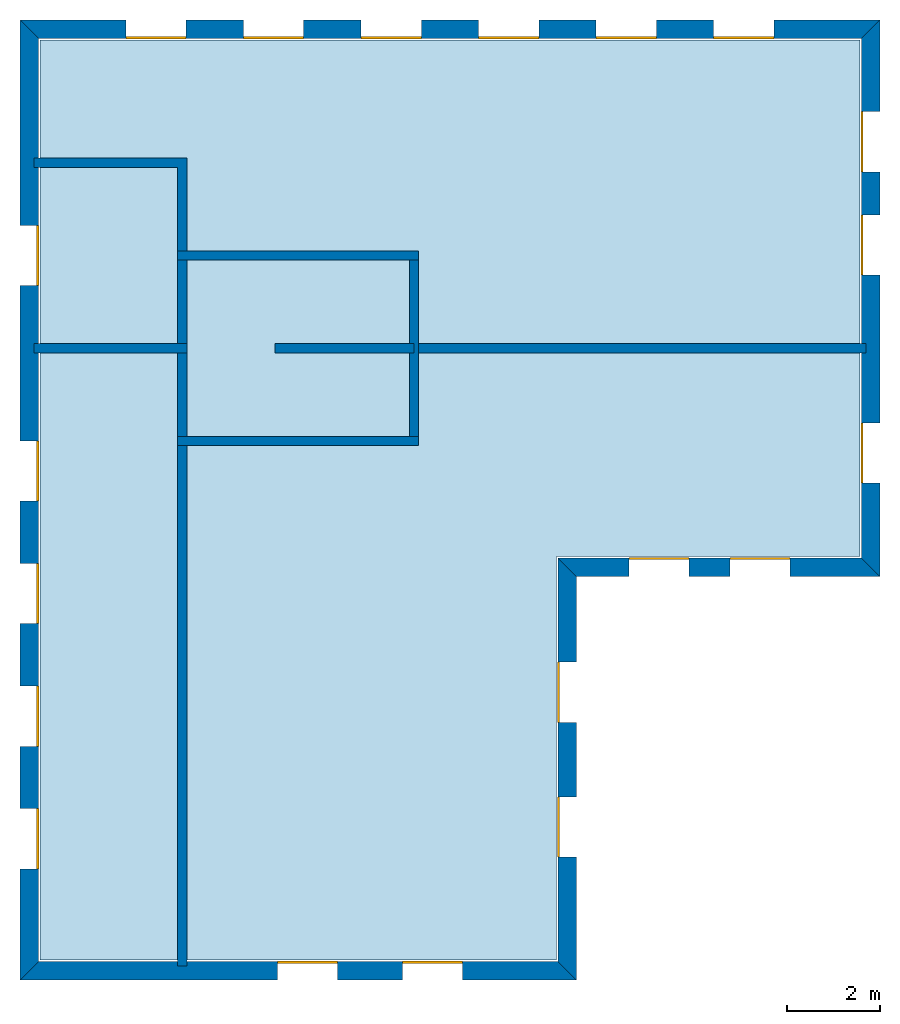
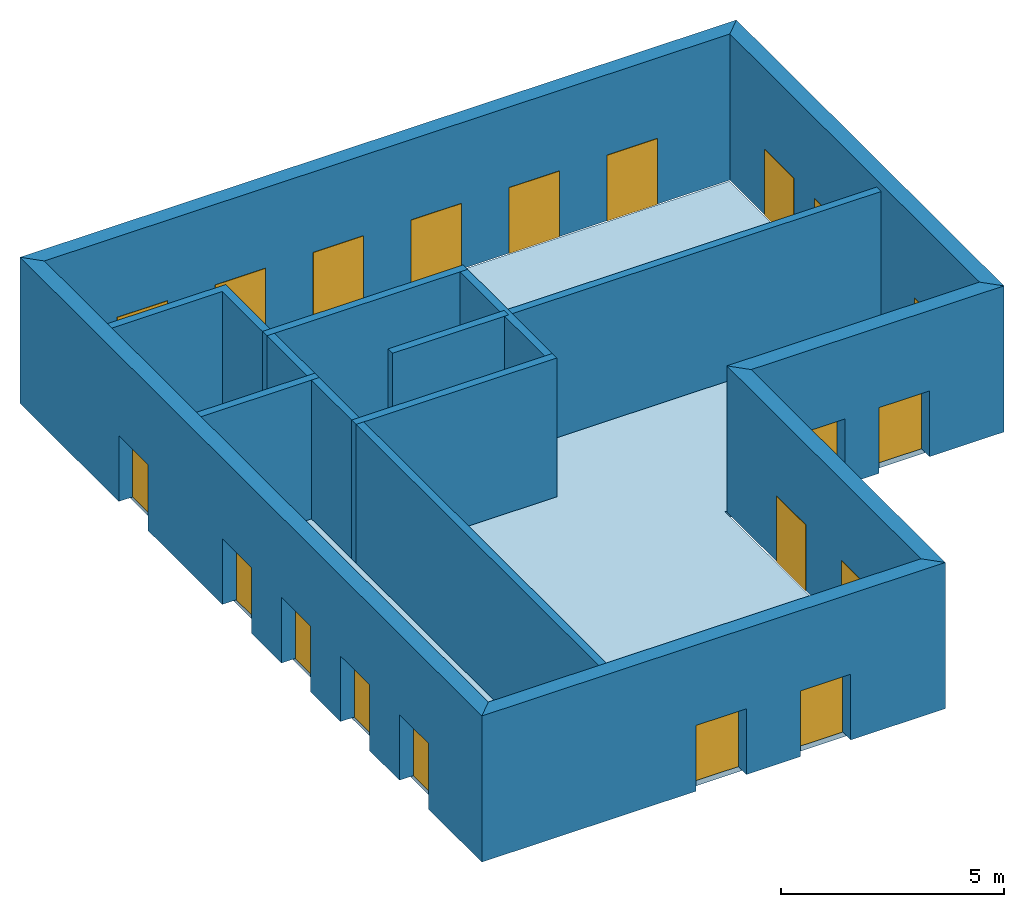
# One storey: 20 windows, 15 walls, 1 slab, 20 openings.
"""IFC4 building model written with IfcOpenShell, lengths in metres."""

from ifc_helpers import new_model, si_unit, origin_with_axes, place, context, subcontext, project, spatial, line, indexed_curve, outline, extrude, element, fill, save


model = new_model("IFC4")

# Units and contexts
model_context = context("Model", 3, precision=1e-05, world=origin_with_axes())
body_context = subcontext(model_context, "Body", "Model", "MODEL_VIEW")
ifc_project = project(units=[si_unit("VOLUMEUNIT", "CUBIC_METRE"), si_unit("LENGTHUNIT", "METRE"), si_unit("AREAUNIT", "SQUARE_METRE")], contexts=[model_context])

# Site, building, storey
site = spatial("IfcSite", under=ifc_project)
building = spatial("IfcBuilding", under=site, Name="Building 1")
storey_placement = place(None, origin_with_axes())
storey = spatial("IfcBuildingStorey", under=building, at=storey_placement, Name="01 Storey")

# Slab
slab_placement = place(storey_placement, origin_with_axes())
element("IfcSlab", 1, at=slab_placement, inside=storey, Name="Slab", context=body_context, shape_type="SweptSolid", body=[
    extrude(outline(indexed_curve([(15.563354, 14.685575), (22.109464, 14.685575), (22.109464, 25.825575), (4.423354, 25.825575), (4.423354, 5.9782), (15.563354, 5.9782)], segments=[line(1, 2), line(2, 3), line(3, 4), line(4, 5), line(5, 6)])), origin_with_axes(), (0.0, 0.0, -1.0), 0.2),
])

# Walls
wall_1_placement = place(storey_placement, origin_with_axes())
element("IfcWall", 2, at=wall_1_placement, inside=storey, Name="Wall", context=body_context, shape_type="SweptSolid", body=[
    extrude(outline(indexed_curve([(22.239464, 19.274943), (12.393354, 19.274943), (12.393354, 19.074943), (22.239464, 19.074943)], segments=[line(1, 2), line(2, 3), line(3, 4)])), origin_with_axes(), (0.0, 0.0, 1.0), 3.8),
])
wall_2_placement = place(storey_placement, origin_with_axes())
element("IfcWall", 3, at=wall_2_placement, inside=storey, Name="Wall", context=body_context, shape_type="SweptSolid", body=[
    extrude(outline(indexed_curve([(7.593354, 17.274943), (7.393354, 17.274943), (7.393354, 5.8482), (7.593354, 5.8482)], segments=[line(1, 2), line(2, 3), line(3, 4)])), origin_with_axes(), (0.0, 0.0, 1.0), 3.8),
])
wall_3_placement = place(storey_placement, origin_with_axes())
element("IfcWall", 4, at=wall_3_placement, inside=storey, Name="Wall", context=body_context, shape_type="SweptSolid", body=[
    extrude(outline(indexed_curve([(7.593354, 19.274943), (4.293354, 19.274943), (4.293354, 19.074943), (7.593354, 19.074943)], segments=[line(1, 2), line(2, 3), line(3, 4)])), origin_with_axes(), (0.0, 0.0, 1.0), 3.8),
])
wall_4_placement = place(storey_placement, origin_with_axes())
element("IfcWall", 5, at=wall_4_placement, inside=storey, Name="Wall", context=body_context, shape_type="SweptSolid", body=[
    extrude(outline(indexed_curve([(7.593354, 23.274943), (4.293354, 23.274943), (4.293354, 23.074943), (7.393354, 23.074943), (7.393354, 21.074943), (7.593354, 21.074943)], segments=[line(1, 2), line(2, 3), line(3, 4), line(4, 5), line(5, 6)])), origin_with_axes(), (0.0, 0.0, 1.0), 3.8),
])

# Wall, openings, windows
wall_5_placement = place(storey_placement, origin_with_axes())
wall_5 = element("IfcWall", 6, at=wall_5_placement, inside=storey, Name="Facade", context=body_context, shape_type="SweptSolid", body=[
    extrude(outline(indexed_curve([(15.593354, 14.655575), (22.139464, 14.655575), (22.539464, 14.255575), (15.993354, 14.255575)], segments=[line(1, 2), line(2, 3), line(3, 4)])), origin_with_axes(), (0.0, 0.0, 1.0), 4.0),
])
opening_1_placement = place(wall_5_placement, origin_with_axes())
opening_1 = element("IfcOpeningElement", 7, at=opening_1_placement, cuts=wall_5, Name="Opening", context=body_context, shape_type="SweptSolid", body=[
    extrude(outline(indexed_curve([(17.1253906666667, 14.215575), (17.1253906666667, 14.715575), (18.4253906666667, 14.715575), (18.4253906666667, 14.215575)], segments=[line(1, 2), line(2, 3), line(3, 4)])), origin_with_axes(), (0.0, 0.0, 1.0), 1.8),
])
opening_2_placement = place(wall_5_placement, origin_with_axes())
opening_2 = element("IfcOpeningElement", 8, at=opening_2_placement, cuts=wall_5, Name="Opening", context=body_context, shape_type="SweptSolid", body=[
    extrude(outline(indexed_curve([(19.3074273333333, 14.215575), (19.3074273333333, 14.715575), (20.6074273333333, 14.715575), (20.6074273333333, 14.215575)], segments=[line(1, 2), line(2, 3), line(3, 4)])), origin_with_axes(), (0.0, 0.0, 1.0), 1.8),
])
window_1_placement = place(storey_placement, origin_with_axes())
window_1 = element("IfcWindow", 9, at=window_1_placement, inside=storey, Name="Window", PredefinedType="WINDOW", context=body_context, shape_type="SweptSolid", body=[
    extrude(outline(indexed_curve([(17.1253906666667, 14.615575), (17.1253906666667, 14.665575), (18.4253906666667, 14.665575), (18.4253906666667, 14.615575)], segments=[line(1, 2), line(2, 3), line(3, 4)])), origin_with_axes(), (0.0, 0.0, 1.0), 1.8),
])
fill(opening_1, window_1)
window_2_placement = place(storey_placement, origin_with_axes())
window_2 = element("IfcWindow", 10, at=window_2_placement, inside=storey, Name="Window", PredefinedType="WINDOW", context=body_context, shape_type="SweptSolid", body=[
    extrude(outline(indexed_curve([(19.3074273333333, 14.615575), (19.3074273333333, 14.665575), (20.6074273333333, 14.665575), (20.6074273333333, 14.615575)], segments=[line(1, 2), line(2, 3), line(3, 4)])), origin_with_axes(), (0.0, 0.0, 1.0), 1.8),
])
fill(opening_2, window_2)

wall_6_placement = place(storey_placement, origin_with_axes())
wall_6 = element("IfcWall", 11, at=wall_6_placement, inside=storey, Name="Facade", context=body_context, shape_type="SweptSolid", body=[
    extrude(outline(indexed_curve([(22.139464, 14.655575), (22.139464, 25.855575), (22.539464, 26.255575), (22.539464, 14.255575)], segments=[line(1, 2), line(2, 3), line(3, 4)])), origin_with_axes(), (0.0, 0.0, 1.0), 4.0),
])
opening_3_placement = place(wall_6_placement, origin_with_axes())
opening_3 = element("IfcOpeningElement", 12, at=opening_3_placement, cuts=wall_6, Name="Opening", context=body_context, shape_type="SweptSolid", body=[
    extrude(outline(indexed_curve([(22.579464, 16.265259), (22.079464, 16.265259), (22.079464, 17.565259), (22.579464, 17.565259)], segments=[line(1, 2), line(2, 3), line(3, 4)])), origin_with_axes(), (0.0, 0.0, 1.0), 1.8),
])
opening_4_placement = place(wall_6_placement, origin_with_axes())
opening_4 = element("IfcOpeningElement", 13, at=opening_4_placement, cuts=wall_6, Name="Opening", context=body_context, shape_type="SweptSolid", body=[
    extrude(outline(indexed_curve([(22.579464, 20.7518203333333), (22.079464, 20.7518203333333), (22.079464, 22.0518203333333), (22.579464, 22.0518203333333)], segments=[line(1, 2), line(2, 3), line(3, 4)])), origin_with_axes(), (0.0, 0.0, 1.0), 1.8),
])
opening_5_placement = place(wall_6_placement, origin_with_axes())
opening_5 = element("IfcOpeningElement", 14, at=opening_5_placement, cuts=wall_6, Name="Opening", context=body_context, shape_type="SweptSolid", body=[
    extrude(outline(indexed_curve([(22.579464, 22.9786976666667), (22.079464, 22.9786976666667), (22.079464, 24.2786976666667), (22.579464, 24.2786976666667)], segments=[line(1, 2), line(2, 3), line(3, 4)])), origin_with_axes(), (0.0, 0.0, 1.0), 1.8),
])
window_3_placement = place(storey_placement, origin_with_axes())
window_3 = element("IfcWindow", 15, at=window_3_placement, inside=storey, Name="Window", PredefinedType="WINDOW", context=body_context, shape_type="SweptSolid", body=[
    extrude(outline(indexed_curve([(22.179464, 16.265259), (22.129464, 16.265259), (22.129464, 17.565259), (22.179464, 17.565259)], segments=[line(1, 2), line(2, 3), line(3, 4)])), origin_with_axes(), (0.0, 0.0, 1.0), 1.8),
])
fill(opening_3, window_3)
window_4_placement = place(storey_placement, origin_with_axes())
window_4 = element("IfcWindow", 16, at=window_4_placement, inside=storey, Name="Window", PredefinedType="WINDOW", context=body_context, shape_type="SweptSolid", body=[
    extrude(outline(indexed_curve([(22.179464, 20.7518203333333), (22.129464, 20.7518203333333), (22.129464, 22.0518203333333), (22.179464, 22.0518203333333)], segments=[line(1, 2), line(2, 3), line(3, 4)])), origin_with_axes(), (0.0, 0.0, 1.0), 1.8),
])
fill(opening_4, window_4)
window_5_placement = place(storey_placement, origin_with_axes())
window_5 = element("IfcWindow", 17, at=window_5_placement, inside=storey, Name="Window", PredefinedType="WINDOW", context=body_context, shape_type="SweptSolid", body=[
    extrude(outline(indexed_curve([(22.179464, 22.9786976666667), (22.129464, 22.9786976666667), (22.129464, 24.2786976666667), (22.179464, 24.2786976666667)], segments=[line(1, 2), line(2, 3), line(3, 4)])), origin_with_axes(), (0.0, 0.0, 1.0), 1.8),
])
fill(opening_5, window_5)

wall_7_placement = place(storey_placement, origin_with_axes())
wall_7 = element("IfcWall", 18, at=wall_7_placement, inside=storey, Name="Facade", context=body_context, shape_type="SweptSolid", body=[
    extrude(outline(indexed_curve([(22.139464, 25.855575), (4.393354, 25.855575), (3.993354, 26.255575), (22.539464, 26.255575)], segments=[line(1, 2), line(2, 3), line(3, 4)])), origin_with_axes(), (0.0, 0.0, 1.0), 4.0),
])
opening_6_placement = place(wall_7_placement, origin_with_axes())
opening_6 = element("IfcOpeningElement", 19, at=opening_6_placement, cuts=wall_7, Name="Opening", context=body_context, shape_type="SweptSolid", body=[
    extrude(outline(indexed_curve([(20.2543054285714, 26.295575), (20.2543054285714, 25.795575), (18.9543054285714, 25.795575), (18.9543054285714, 26.295575)], segments=[line(1, 2), line(2, 3), line(3, 4)])), origin_with_axes(), (0.0, 0.0, 1.0), 1.8),
])
opening_7_placement = place(wall_7_placement, origin_with_axes())
opening_7 = element("IfcOpeningElement", 20, at=opening_7_placement, cuts=wall_7, Name="Opening", context=body_context, shape_type="SweptSolid", body=[
    extrude(outline(indexed_curve([(17.7191468571429, 26.295575), (17.7191468571429, 25.795575), (16.4191468571429, 25.795575), (16.4191468571429, 26.295575)], segments=[line(1, 2), line(2, 3), line(3, 4)])), origin_with_axes(), (0.0, 0.0, 1.0), 1.8),
])
opening_8_placement = place(wall_7_placement, origin_with_axes())
opening_8 = element("IfcOpeningElement", 21, at=opening_8_placement, cuts=wall_7, Name="Opening", context=body_context, shape_type="SweptSolid", body=[
    extrude(outline(indexed_curve([(15.1839882857143, 26.295575), (15.1839882857143, 25.795575), (13.8839882857143, 25.795575), (13.8839882857143, 26.295575)], segments=[line(1, 2), line(2, 3), line(3, 4)])), origin_with_axes(), (0.0, 0.0, 1.0), 1.8),
])
opening_9_placement = place(wall_7_placement, origin_with_axes())
opening_9 = element("IfcOpeningElement", 22, at=opening_9_placement, cuts=wall_7, Name="Opening", context=body_context, shape_type="SweptSolid", body=[
    extrude(outline(indexed_curve([(12.6488297142857, 26.295575), (12.6488297142857, 25.795575), (11.3488297142857, 25.795575), (11.3488297142857, 26.295575)], segments=[line(1, 2), line(2, 3), line(3, 4)])), origin_with_axes(), (0.0, 0.0, 1.0), 1.8),
])
opening_10_placement = place(wall_7_placement, origin_with_axes())
opening_10 = element("IfcOpeningElement", 23, at=opening_10_placement, cuts=wall_7, Name="Opening", context=body_context, shape_type="SweptSolid", body=[
    extrude(outline(indexed_curve([(10.1136711428571, 26.295575), (10.1136711428571, 25.795575), (8.81367114285714, 25.795575), (8.81367114285714, 26.295575)], segments=[line(1, 2), line(2, 3), line(3, 4)])), origin_with_axes(), (0.0, 0.0, 1.0), 1.8),
])
opening_11_placement = place(wall_7_placement, origin_with_axes())
opening_11 = element("IfcOpeningElement", 24, at=opening_11_placement, cuts=wall_7, Name="Opening", context=body_context, shape_type="SweptSolid", body=[
    extrude(outline(indexed_curve([(7.57851257142857, 26.295575), (7.57851257142857, 25.795575), (6.27851257142857, 25.795575), (6.27851257142857, 26.295575)], segments=[line(1, 2), line(2, 3), line(3, 4)])), origin_with_axes(), (0.0, 0.0, 1.0), 1.8),
])
window_6_placement = place(storey_placement, origin_with_axes())
window_6 = element("IfcWindow", 25, at=window_6_placement, inside=storey, Name="Window", PredefinedType="WINDOW", context=body_context, shape_type="SweptSolid", body=[
    extrude(outline(indexed_curve([(20.2543054285714, 25.895575), (20.2543054285714, 25.845575), (18.9543054285714, 25.845575), (18.9543054285714, 25.895575)], segments=[line(1, 2), line(2, 3), line(3, 4)])), origin_with_axes(), (0.0, 0.0, 1.0), 1.8),
])
fill(opening_6, window_6)
window_7_placement = place(storey_placement, origin_with_axes())
window_7 = element("IfcWindow", 26, at=window_7_placement, inside=storey, Name="Window", PredefinedType="WINDOW", context=body_context, shape_type="SweptSolid", body=[
    extrude(outline(indexed_curve([(17.7191468571429, 25.895575), (17.7191468571429, 25.845575), (16.4191468571429, 25.845575), (16.4191468571429, 25.895575)], segments=[line(1, 2), line(2, 3), line(3, 4)])), origin_with_axes(), (0.0, 0.0, 1.0), 1.8),
])
fill(opening_7, window_7)
window_8_placement = place(storey_placement, origin_with_axes())
window_8 = element("IfcWindow", 27, at=window_8_placement, inside=storey, Name="Window", PredefinedType="WINDOW", context=body_context, shape_type="SweptSolid", body=[
    extrude(outline(indexed_curve([(15.1839882857143, 25.895575), (15.1839882857143, 25.845575), (13.8839882857143, 25.845575), (13.8839882857143, 25.895575)], segments=[line(1, 2), line(2, 3), line(3, 4)])), origin_with_axes(), (0.0, 0.0, 1.0), 1.8),
])
fill(opening_8, window_8)
window_9_placement = place(storey_placement, origin_with_axes())
window_9 = element("IfcWindow", 28, at=window_9_placement, inside=storey, Name="Window", PredefinedType="WINDOW", context=body_context, shape_type="SweptSolid", body=[
    extrude(outline(indexed_curve([(12.6488297142857, 25.895575), (12.6488297142857, 25.845575), (11.3488297142857, 25.845575), (11.3488297142857, 25.895575)], segments=[line(1, 2), line(2, 3), line(3, 4)])), origin_with_axes(), (0.0, 0.0, 1.0), 1.8),
])
fill(opening_9, window_9)
window_10_placement = place(storey_placement, origin_with_axes())
window_10 = element("IfcWindow", 29, at=window_10_placement, inside=storey, Name="Window", PredefinedType="WINDOW", context=body_context, shape_type="SweptSolid", body=[
    extrude(outline(indexed_curve([(10.1136711428571, 25.895575), (10.1136711428571, 25.845575), (8.81367114285714, 25.845575), (8.81367114285714, 25.895575)], segments=[line(1, 2), line(2, 3), line(3, 4)])), origin_with_axes(), (0.0, 0.0, 1.0), 1.8),
])
fill(opening_10, window_10)
window_11_placement = place(storey_placement, origin_with_axes())
window_11 = element("IfcWindow", 30, at=window_11_placement, inside=storey, Name="Window", PredefinedType="WINDOW", context=body_context, shape_type="SweptSolid", body=[
    extrude(outline(indexed_curve([(7.57851257142857, 25.895575), (7.57851257142857, 25.845575), (6.27851257142857, 25.845575), (6.27851257142857, 25.895575)], segments=[line(1, 2), line(2, 3), line(3, 4)])), origin_with_axes(), (0.0, 0.0, 1.0), 1.8),
])
fill(opening_11, window_11)

wall_8_placement = place(storey_placement, origin_with_axes())
wall_8 = element("IfcWall", 31, at=wall_8_placement, inside=storey, Name="Facade", context=body_context, shape_type="SweptSolid", body=[
    extrude(outline(indexed_curve([(4.393354, 25.855575), (4.393354, 5.9482), (3.993354, 5.5482), (3.993354, 26.255575)], segments=[line(1, 2), line(2, 3), line(3, 4)])), origin_with_axes(), (0.0, 0.0, 1.0), 4.0),
])
opening_12_placement = place(wall_8_placement, origin_with_axes())
opening_12 = element("IfcOpeningElement", 32, at=opening_12_placement, cuts=wall_8, Name="Opening", context=body_context, shape_type="SweptSolid", body=[
    extrude(outline(indexed_curve([(3.953354, 17.1795944), (4.453354, 17.1795944), (4.453354, 15.8795944), (3.953354, 15.8795944)], segments=[line(1, 2), line(2, 3), line(3, 4)])), origin_with_axes(), (0.0, 0.0, 1.0), 1.8),
])
opening_13_placement = place(wall_8_placement, origin_with_axes())
opening_13 = element("IfcOpeningElement", 33, at=opening_13_placement, cuts=wall_8, Name="Opening", context=body_context, shape_type="SweptSolid", body=[
    extrude(outline(indexed_curve([(3.953354, 14.5342458), (4.453354, 14.5342458), (4.453354, 13.2342458), (3.953354, 13.2342458)], segments=[line(1, 2), line(2, 3), line(3, 4)])), origin_with_axes(), (0.0, 0.0, 1.0), 1.8),
])
opening_14_placement = place(wall_8_placement, origin_with_axes())
opening_14 = element("IfcOpeningElement", 34, at=opening_14_placement, cuts=wall_8, Name="Opening", context=body_context, shape_type="SweptSolid", body=[
    extrude(outline(indexed_curve([(3.953354, 11.8888972), (4.453354, 11.8888972), (4.453354, 10.5888972), (3.953354, 10.5888972)], segments=[line(1, 2), line(2, 3), line(3, 4)])), origin_with_axes(), (0.0, 0.0, 1.0), 1.8),
])
opening_15_placement = place(wall_8_placement, origin_with_axes())
opening_15 = element("IfcOpeningElement", 35, at=opening_15_placement, cuts=wall_8, Name="Opening", context=body_context, shape_type="SweptSolid", body=[
    extrude(outline(indexed_curve([(3.953354, 9.2435486), (4.453354, 9.2435486), (4.453354, 7.9435486), (3.953354, 7.9435486)], segments=[line(1, 2), line(2, 3), line(3, 4)])), origin_with_axes(), (0.0, 0.0, 1.0), 1.8),
])
opening_16_placement = place(wall_8_placement, origin_with_axes())
opening_16 = element("IfcOpeningElement", 36, at=opening_16_placement, cuts=wall_8, Name="Opening", context=body_context, shape_type="SweptSolid", body=[
    extrude(outline(indexed_curve([(3.953354, 21.824943), (4.453354, 21.824943), (4.453354, 20.524943), (3.953354, 20.524943)], segments=[line(1, 2), line(2, 3), line(3, 4)])), origin_with_axes(), (0.0, 0.0, 1.0), 1.8),
])
window_12_placement = place(storey_placement, origin_with_axes())
window_12 = element("IfcWindow", 37, at=window_12_placement, inside=storey, Name="Window", PredefinedType="WINDOW", context=body_context, shape_type="SweptSolid", body=[
    extrude(outline(indexed_curve([(4.353354, 17.1795944), (4.403354, 17.1795944), (4.403354, 15.8795944), (4.353354, 15.8795944)], segments=[line(1, 2), line(2, 3), line(3, 4)])), origin_with_axes(), (0.0, 0.0, 1.0), 1.8),
])
fill(opening_12, window_12)
window_13_placement = place(storey_placement, origin_with_axes())
window_13 = element("IfcWindow", 38, at=window_13_placement, inside=storey, Name="Window", PredefinedType="WINDOW", context=body_context, shape_type="SweptSolid", body=[
    extrude(outline(indexed_curve([(4.353354, 14.5342458), (4.403354, 14.5342458), (4.403354, 13.2342458), (4.353354, 13.2342458)], segments=[line(1, 2), line(2, 3), line(3, 4)])), origin_with_axes(), (0.0, 0.0, 1.0), 1.8),
])
fill(opening_13, window_13)
window_14_placement = place(storey_placement, origin_with_axes())
window_14 = element("IfcWindow", 39, at=window_14_placement, inside=storey, Name="Window", PredefinedType="WINDOW", context=body_context, shape_type="SweptSolid", body=[
    extrude(outline(indexed_curve([(4.353354, 11.8888972), (4.403354, 11.8888972), (4.403354, 10.5888972), (4.353354, 10.5888972)], segments=[line(1, 2), line(2, 3), line(3, 4)])), origin_with_axes(), (0.0, 0.0, 1.0), 1.8),
])
fill(opening_14, window_14)
window_15_placement = place(storey_placement, origin_with_axes())
window_15 = element("IfcWindow", 40, at=window_15_placement, inside=storey, Name="Window", PredefinedType="WINDOW", context=body_context, shape_type="SweptSolid", body=[
    extrude(outline(indexed_curve([(4.353354, 9.2435486), (4.403354, 9.2435486), (4.403354, 7.9435486), (4.353354, 7.9435486)], segments=[line(1, 2), line(2, 3), line(3, 4)])), origin_with_axes(), (0.0, 0.0, 1.0), 1.8),
])
fill(opening_15, window_15)
window_16_placement = place(storey_placement, origin_with_axes())
window_16 = element("IfcWindow", 41, at=window_16_placement, inside=storey, Name="Window", PredefinedType="WINDOW", context=body_context, shape_type="SweptSolid", body=[
    extrude(outline(indexed_curve([(4.353354, 21.824943), (4.403354, 21.824943), (4.403354, 20.524943), (4.353354, 20.524943)], segments=[line(1, 2), line(2, 3), line(3, 4)])), origin_with_axes(), (0.0, 0.0, 1.0), 1.8),
])
fill(opening_16, window_16)

wall_9_placement = place(storey_placement, origin_with_axes())
wall_9 = element("IfcWall", 42, at=wall_9_placement, inside=storey, Name="Facade", context=body_context, shape_type="SweptSolid", body=[
    extrude(outline(indexed_curve([(4.393354, 5.9482), (15.593354, 5.9482), (15.993354, 5.5482), (3.993354, 5.5482)], segments=[line(1, 2), line(2, 3), line(3, 4)])), origin_with_axes(), (0.0, 0.0, 1.0), 4.0),
])
opening_17_placement = place(wall_9_placement, origin_with_axes())
opening_17 = element("IfcOpeningElement", 43, at=opening_17_placement, cuts=wall_9, Name="Opening", context=body_context, shape_type="SweptSolid", body=[
    extrude(outline(indexed_curve([(9.543354, 5.5082), (9.543354, 6.0082), (10.843354, 6.0082), (10.843354, 5.5082)], segments=[line(1, 2), line(2, 3), line(3, 4)])), origin_with_axes(), (0.0, 0.0, 1.0), 1.8),
])
opening_18_placement = place(wall_9_placement, origin_with_axes())
opening_18 = element("IfcOpeningElement", 44, at=opening_18_placement, cuts=wall_9, Name="Opening", context=body_context, shape_type="SweptSolid", body=[
    extrude(outline(indexed_curve([(12.243354, 5.5082), (12.243354, 6.0082), (13.543354, 6.0082), (13.543354, 5.5082)], segments=[line(1, 2), line(2, 3), line(3, 4)])), origin_with_axes(), (0.0, 0.0, 1.0), 1.8),
])
window_17_placement = place(storey_placement, origin_with_axes())
window_17 = element("IfcWindow", 45, at=window_17_placement, inside=storey, Name="Window", PredefinedType="WINDOW", context=body_context, shape_type="SweptSolid", body=[
    extrude(outline(indexed_curve([(9.543354, 5.9082), (9.543354, 5.9582), (10.843354, 5.9582), (10.843354, 5.9082)], segments=[line(1, 2), line(2, 3), line(3, 4)])), origin_with_axes(), (0.0, 0.0, 1.0), 1.8),
])
fill(opening_17, window_17)
window_18_placement = place(storey_placement, origin_with_axes())
window_18 = element("IfcWindow", 46, at=window_18_placement, inside=storey, Name="Window", PredefinedType="WINDOW", context=body_context, shape_type="SweptSolid", body=[
    extrude(outline(indexed_curve([(12.243354, 5.9082), (12.243354, 5.9582), (13.543354, 5.9582), (13.543354, 5.9082)], segments=[line(1, 2), line(2, 3), line(3, 4)])), origin_with_axes(), (0.0, 0.0, 1.0), 1.8),
])
fill(opening_18, window_18)

wall_10_placement = place(storey_placement, origin_with_axes())
wall_10 = element("IfcWall", 47, at=wall_10_placement, inside=storey, Name="Facade", context=body_context, shape_type="SweptSolid", body=[
    extrude(outline(indexed_curve([(15.593354, 5.9482), (15.593354, 14.655575), (15.993354, 14.255575), (15.993354, 5.5482)], segments=[line(1, 2), line(2, 3), line(3, 4)])), origin_with_axes(), (0.0, 0.0, 1.0), 4.0),
])
opening_19_placement = place(wall_10_placement, origin_with_axes())
opening_19 = element("IfcOpeningElement", 48, at=opening_19_placement, cuts=wall_10, Name="Opening", context=body_context, shape_type="SweptSolid", body=[
    extrude(outline(indexed_curve([(16.033354, 8.20065833333333), (15.533354, 8.20065833333333), (15.533354, 9.50065833333333), (16.033354, 9.50065833333333)], segments=[line(1, 2), line(2, 3), line(3, 4)])), origin_with_axes(), (0.0, 0.0, 1.0), 1.8),
])
opening_20_placement = place(wall_10_placement, origin_with_axes())
opening_20 = element("IfcOpeningElement", 49, at=opening_20_placement, cuts=wall_10, Name="Opening", context=body_context, shape_type="SweptSolid", body=[
    extrude(outline(indexed_curve([(16.033354, 11.1031166666667), (15.533354, 11.1031166666667), (15.533354, 12.4031166666667), (16.033354, 12.4031166666667)], segments=[line(1, 2), line(2, 3), line(3, 4)])), origin_with_axes(), (0.0, 0.0, 1.0), 1.8),
])
window_19_placement = place(storey_placement, origin_with_axes())
window_19 = element("IfcWindow", 50, at=window_19_placement, inside=storey, Name="Window", PredefinedType="WINDOW", context=body_context, shape_type="SweptSolid", body=[
    extrude(outline(indexed_curve([(15.633354, 8.20065833333333), (15.583354, 8.20065833333333), (15.583354, 9.50065833333333), (15.633354, 9.50065833333333)], segments=[line(1, 2), line(2, 3), line(3, 4)])), origin_with_axes(), (0.0, 0.0, 1.0), 1.8),
])
fill(opening_19, window_19)
window_20_placement = place(storey_placement, origin_with_axes())
window_20 = element("IfcWindow", 51, at=window_20_placement, inside=storey, Name="Window", PredefinedType="WINDOW", context=body_context, shape_type="SweptSolid", body=[
    extrude(outline(indexed_curve([(15.633354, 11.1031166666667), (15.583354, 11.1031166666667), (15.583354, 12.4031166666667), (15.633354, 12.4031166666667)], segments=[line(1, 2), line(2, 3), line(3, 4)])), origin_with_axes(), (0.0, 0.0, 1.0), 1.8),
])
fill(opening_20, window_20)

# Walls
wall_11_placement = place(storey_placement, origin_with_axes())
element("IfcWall", 52, at=wall_11_placement, inside=storey, Name="CoreWall", context=body_context, shape_type="SweptSolid", body=[
    extrude(outline(indexed_curve([(12.593354, 21.274943), (7.393354, 21.274943), (7.393354, 21.074943), (12.593354, 21.074943)], segments=[line(1, 2), line(2, 3), line(3, 4)])), origin_with_axes(), (0.0, 0.0, 1.0), 3.8),
])
wall_12_placement = place(storey_placement, origin_with_axes())
element("IfcWall", 53, at=wall_12_placement, inside=storey, Name="CoreWall", context=body_context, shape_type="SweptSolid", body=[
    extrude(outline(indexed_curve([(7.393354, 17.074943), (12.593354, 17.074943), (12.593354, 17.274943), (7.393354, 17.274943)], segments=[line(1, 2), line(2, 3), line(3, 4)])), origin_with_axes(), (0.0, 0.0, 1.0), 3.8),
])
wall_13_placement = place(storey_placement, origin_with_axes())
element("IfcWall", 54, at=wall_13_placement, inside=storey, Name="CoreWall", context=body_context, shape_type="SweptSolid", body=[
    extrude(outline(indexed_curve([(7.593354, 17.274943), (7.593354, 21.074943), (7.393354, 21.074943), (7.393354, 17.274943)], segments=[line(1, 2), line(2, 3), line(3, 4)])), origin_with_axes(), (0.0, 0.0, 1.0), 3.8),
])
wall_14_placement = place(storey_placement, origin_with_axes())
element("IfcWall", 55, at=wall_14_placement, inside=storey, Name="CoreWall", context=body_context, shape_type="SweptSolid", body=[
    extrude(outline(indexed_curve([(12.393354, 21.074943), (12.393354, 17.274943), (12.593354, 17.274943), (12.593354, 21.074943)], segments=[line(1, 2), line(2, 3), line(3, 4)])), origin_with_axes(), (0.0, 0.0, 1.0), 3.8),
])
wall_15_placement = place(storey_placement, origin_with_axes())
element("IfcWall", 56, at=wall_15_placement, inside=storey, Name="CoreWall", context=body_context, shape_type="SweptSolid", body=[
    extrude(outline(indexed_curve([(12.493354, 19.274943), (9.493354, 19.274943), (9.493354, 19.074943), (12.493354, 19.074943)], segments=[line(1, 2), line(2, 3), line(3, 4)])), origin_with_axes(), (0.0, 0.0, 1.0), 3.8),
])

save(model, "model.ifc")
